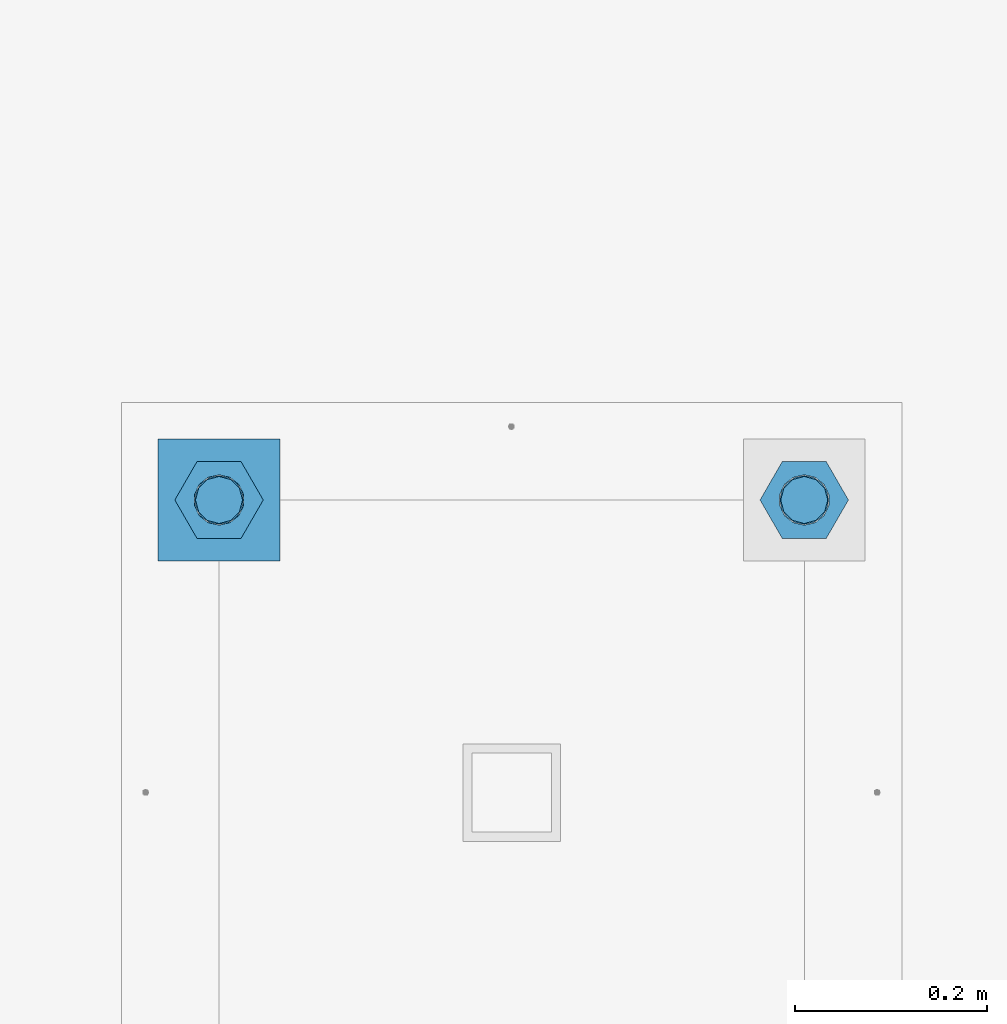
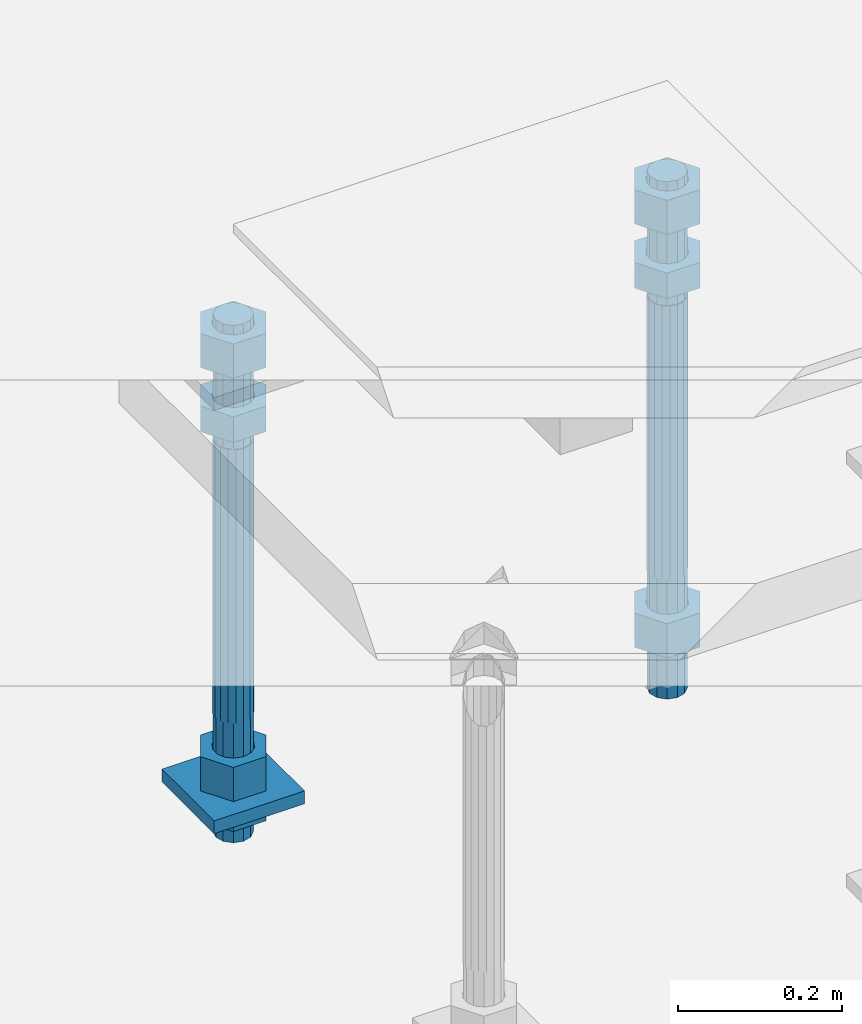
# One storey, part 2715 of 3843: 10 beams, 1 element without a shape of its own.
"""IFC2X3 building model written with IfcOpenShell, lengths in millimetres."""

from ifc_helpers import new_model, si_unit, frame, origin_with_axes, place, context, subcontext, project, spatial, faceted_brep, material, type_object, element, aggregate, save


model = new_model("IFC2X3")

# Units and contexts
model_context = context("Model", 3, precision=1e-05, world=origin_with_axes())
body_context = subcontext(model_context, "Body", "Model", "MODEL_VIEW")
ifc_project = project(units=[si_unit("LENGTHUNIT", "METRE", prefix="MILLI"), si_unit("AREAUNIT", "SQUARE_METRE"), si_unit("VOLUMEUNIT", "CUBIC_METRE"), si_unit("MASSUNIT", "GRAM", prefix="KILO"), si_unit("TIMEUNIT", "SECOND"), si_unit("PLANEANGLEUNIT", "RADIAN"), si_unit("SOLIDANGLEUNIT", "STERADIAN"), si_unit("THERMODYNAMICTEMPERATUREUNIT", "DEGREE_CELSIUS"), si_unit("LUMINOUSINTENSITYUNIT", "LUMEN")], contexts=[model_context])

# Site, building, storey
site_placement = place(None, origin_with_axes())
site = spatial("IfcSite", under=ifc_project, at=site_placement, CompositionType="ELEMENT")
building_placement = place(site_placement, origin_with_axes())
building = spatial("IfcBuilding", under=site, at=building_placement, Name="Undefined", CompositionType="ELEMENT")
storey_placement = place(building_placement, origin_with_axes())
storey = spatial("IfcBuildingStorey", under=building, at=storey_placement, Name="Undefined", CompositionType="ELEMENT", Elevation=0.0)

# Assembly, beams
assembly_placement = place(storey_placement, origin_with_axes())
assembly = element("IfcElementAssembly", 1, at=assembly_placement, inside=storey, Name="TEMPLATE", AssemblyPlace="NOTDEFINED", PredefinedType="RIGID_FRAME")
ifc_material_1 = material(Name="STEEL/A36")
beam_type_1 = type_object("IfcBeamType", PredefinedType="NOTDEFINED")
beam_1_placement = place(assembly_placement, frame((108648.5, 48869.6000015259, 29244.925), z_axis=(1.0, 0.0, 0.0), x_axis=(0.0, 1.0, 0.0)))
beam_1 = element("IfcBeam", 2, at=beam_1_placement, type_object=beam_type_1, material=ifc_material_1, Name="WASHER_PLATE", context=body_context, shape_type="Brep", body=[
    faceted_brep([(0.0, 9.52500000000146, -63.5), (0.0, 9.52500000000146, 63.5), (127.0, 9.52500000000146, 63.5), (127.0, 9.52500000000146, -63.5), (0.0, -9.52500000000146, 63.5), (127.0, -9.52500000000146, 63.5), (0.0, -9.52500000000146, -63.5), (127.0, -9.52500000000146, -63.5)], [[[0, 1, 2, 3]], [[1, 4, 5, 2]], [[4, 6, 7, 5]], [[6, 0, 3, 7]], [[5, 7, 3, 2]], [[6, 4, 1, 0]]]),
])
beam_type_2 = type_object("IfcBeamType", Name="2_HALF_NUT", PredefinedType="NOTDEFINED")
beam_2_placement = place(assembly_placement, frame((108648.5, 48933.1000015259, 29235.4), z_axis=(0.0, 1.0, 0.0), x_axis=(0.0, 0.0, -1.0)))
beam_2 = element("IfcBeam", 3, at=beam_2_placement, type_object=beam_type_2, material=ifc_material_1, Name="NUT", ObjectType="2_HALF_NUT", context=body_context, shape_type="Brep", body=[
    faceted_brep([(0.0, -46.0369987487793, 0.0), (0.0, -23.0184993743896, -39.869213104248), (25.4000000000015, -23.0184993743896, -39.869213104248), (25.4000000000015, -46.0369987487793, 0.0), (0.0, 23.0184993743896, -39.869213104248), (25.4000000000015, 23.0184993743896, -39.869213104248), (0.0, 46.0369987487793, 0.0), (25.4000000000015, 46.0369987487793, 0.0), (0.0, 23.0184993743896, 39.869213104248), (25.4000000000015, 23.0184993743896, 39.869213104248), (0.0, -23.0184993743896, 39.869213104248), (25.4000000000015, -23.0184993743896, 39.869213104248), (0.0, 0.0, 26.1940002441406), (0.0, 11.3650617044477, 23.5999013092805), (25.4000000000015, 11.3650617044477, 23.5999013092805), (25.4000000000015, 0.0, 26.1940002441406), (0.0, 20.4791109456419, 16.3316083006721), (25.4000000000015, 20.4791109456419, 16.3316083006721), (0.0, 25.5370200498292, 5.82867859874386), (25.4000000000015, 25.5370200498292, 5.82867859874386), (0.0, 25.5370200498292, -5.82867859874386), (25.4000000000015, 25.5370200498292, -5.82867859874386), (0.0, 20.4791109456419, -16.3316083006721), (25.4000000000015, 20.4791109456419, -16.3316083006721), (0.0, 11.3650617044477, -23.5999013092805), (25.4000000000015, 11.3650617044477, -23.5999013092805), (0.0, 0.0, -26.1940002441406), (25.4000000000015, 0.0, -26.1940002441406), (0.0, -11.3650617044477, -23.5999013092805), (25.4000000000015, -11.3650617044477, -23.5999013092805), (0.0, -20.4791109456419, -16.3316083006721), (25.4000000000015, -20.4791109456419, -16.3316083006721), (0.0, -25.5370200498292, -5.82867859874386), (25.4000000000015, -25.5370200498292, -5.82867859874386), (0.0, -25.5370200498292, 5.82867859874386), (25.4000000000015, -25.5370200498292, 5.82867859874386), (0.0, -20.4791109456419, 16.3316083006721), (25.4000000000015, -20.4791109456419, 16.3316083006721), (0.0, -11.3650617044477, 23.5999013092805), (25.4000000000015, -11.3650617044477, 23.5999013092805)], [[[0, 1, 2, 3]], [[1, 4, 5, 2]], [[4, 6, 7, 5]], [[6, 8, 9, 7]], [[8, 10, 11, 9]], [[10, 0, 3, 11]], [[12, 13, 14, 15]], [[13, 16, 17, 14]], [[16, 18, 19, 17]], [[18, 20, 21, 19]], [[20, 22, 23, 21]], [[22, 24, 25, 23]], [[24, 26, 27, 25]], [[26, 28, 29, 27]], [[28, 30, 31, 29]], [[30, 32, 33, 31]], [[32, 34, 35, 33]], [[34, 36, 37, 35]], [[36, 38, 39, 37]], [[38, 12, 15, 39]], [[5, 7, 9, 11, 3, 2], [17, 19, 21, 23, 25, 27, 29, 31, 33, 35, 37, 39, 15, 14]], [[10, 8, 6, 4, 1, 0], [38, 36, 34, 32, 30, 28, 26, 24, 22, 20, 18, 16, 13, 12]]]),
])
beam_type_3 = type_object("IfcBeamType", Name="2_HEAVY_HEX_NUT", PredefinedType="NOTDEFINED")
beam_3_placement = place(assembly_placement, frame((108648.5, 48933.1000015259, 29825.95), z_axis=(0.0, 1.0, 0.0), x_axis=(0.0, 0.0, -1.0)))
beam_3 = element("IfcBeam", 4, at=beam_3_placement, type_object=beam_type_3, material=ifc_material_1, Name="NUT", ObjectType="2_HEAVY_HEX_NUT", context=body_context, shape_type="Brep", body=[
    faceted_brep([(0.0, -46.0369987487793, 0.0), (0.0, -23.0184993743896, -39.869213104248), (38.0999999999985, -23.0184993743896, -39.869213104248), (38.0999999999985, -46.0369987487793, 0.0), (0.0, 23.0184993743896, -39.869213104248), (38.0999999999985, 23.0184993743896, -39.869213104248), (0.0, 46.0369987487793, 0.0), (38.0999999999985, 46.0369987487793, 0.0), (0.0, 23.0184993743896, 39.869213104248), (38.0999999999985, 23.0184993743896, 39.869213104248), (0.0, -23.0184993743896, 39.869213104248), (38.0999999999985, -23.0184993743896, 39.869213104248), (0.0, 0.0, 26.1940002441406), (0.0, 11.3650617044477, 23.5999013092805), (38.0999999999985, 11.3650617044477, 23.5999013092805), (38.0999999999985, 0.0, 26.1940002441406), (0.0, 20.4791109456419, 16.3316083006721), (38.0999999999985, 20.4791109456419, 16.3316083006721), (0.0, 25.5370200498292, 5.82867859874386), (38.0999999999985, 25.5370200498292, 5.82867859874386), (0.0, 25.5370200498292, -5.82867859874386), (38.0999999999985, 25.5370200498292, -5.82867859874386), (0.0, 20.4791109456419, -16.3316083006721), (38.0999999999985, 20.4791109456419, -16.3316083006721), (0.0, 11.3650617044477, -23.5999013092805), (38.0999999999985, 11.3650617044477, -23.5999013092805), (0.0, 0.0, -26.1940002441406), (38.0999999999985, 0.0, -26.1940002441406), (0.0, -11.3650617044477, -23.5999013092805), (38.0999999999985, -11.3650617044477, -23.5999013092805), (0.0, -20.4791109456419, -16.3316083006721), (38.0999999999985, -20.4791109456419, -16.3316083006721), (0.0, -25.5370200498292, -5.82867859874386), (38.0999999999985, -25.5370200498292, -5.82867859874386), (0.0, -25.5370200498292, 5.82867859874386), (38.0999999999985, -25.5370200498292, 5.82867859874386), (0.0, -20.4791109456419, 16.3316083006721), (38.0999999999985, -20.4791109456419, 16.3316083006721), (0.0, -11.3650617044477, 23.5999013092805), (38.0999999999985, -11.3650617044477, 23.5999013092805)], [[[0, 1, 2, 3]], [[1, 4, 5, 2]], [[4, 6, 7, 5]], [[6, 8, 9, 7]], [[8, 10, 11, 9]], [[10, 0, 3, 11]], [[12, 13, 14, 15]], [[13, 16, 17, 14]], [[16, 18, 19, 17]], [[18, 20, 21, 19]], [[20, 22, 23, 21]], [[22, 24, 25, 23]], [[24, 26, 27, 25]], [[26, 28, 29, 27]], [[28, 30, 31, 29]], [[30, 32, 33, 31]], [[32, 34, 35, 33]], [[34, 36, 37, 35]], [[36, 38, 39, 37]], [[38, 12, 15, 39]], [[5, 7, 9, 11, 3, 2], [17, 19, 21, 23, 25, 27, 29, 31, 33, 35, 37, 39, 15, 14]], [[10, 8, 6, 4, 1, 0], [38, 36, 34, 32, 30, 28, 26, 24, 22, 20, 18, 16, 13, 12]]]),
])
beam_4_placement = place(assembly_placement, frame((108648.5, 48933.1000015259, 29933.9), z_axis=(0.0, 1.0, 0.0), x_axis=(0.0, 0.0, -1.0)))
beam_4 = element("IfcBeam", 5, at=beam_4_placement, type_object=beam_type_3, material=ifc_material_1, Name="NUT", ObjectType="2_HEAVY_HEX_NUT", context=body_context, shape_type="Brep", body=[
    faceted_brep([(0.0, -46.0369987487793, 0.0), (0.0, -23.0184993743896, -39.869213104248), (50.7999999999993, -23.0184993743896, -39.869213104248), (50.7999999999993, -46.0369987487793, 0.0), (0.0, 23.0184993743896, -39.869213104248), (50.7999999999993, 23.0184993743896, -39.869213104248), (0.0, 46.0369987487793, 0.0), (50.7999999999993, 46.0369987487793, 0.0), (0.0, 23.0184993743896, 39.869213104248), (50.7999999999993, 23.0184993743896, 39.869213104248), (0.0, -23.0184993743896, 39.869213104248), (50.7999999999993, -23.0184993743896, 39.869213104248), (0.0, 0.0, 26.1940002441406), (0.0, 11.3650617044477, 23.5999013092805), (50.7999999999993, 11.3650617044477, 23.5999013092805), (50.7999999999993, 0.0, 26.1940002441406), (0.0, 20.4791109456419, 16.3316083006721), (50.7999999999993, 20.4791109456419, 16.3316083006721), (0.0, 25.5370200498292, 5.82867859874386), (50.7999999999993, 25.5370200498292, 5.82867859874386), (0.0, 25.5370200498292, -5.82867859874386), (50.7999999999993, 25.5370200498292, -5.82867859874386), (0.0, 20.4791109456419, -16.3316083006721), (50.7999999999993, 20.4791109456419, -16.3316083006721), (0.0, 11.3650617044477, -23.5999013092805), (50.7999999999993, 11.3650617044477, -23.5999013092805), (0.0, 0.0, -26.1940002441406), (50.7999999999993, 0.0, -26.1940002441406), (0.0, -11.3650617044477, -23.5999013092805), (50.7999999999993, -11.3650617044477, -23.5999013092805), (0.0, -20.4791109456419, -16.3316083006721), (50.7999999999993, -20.4791109456419, -16.3316083006721), (0.0, -25.5370200498292, -5.82867859874386), (50.7999999999993, -25.5370200498292, -5.82867859874386), (0.0, -25.5370200498292, 5.82867859874386), (50.7999999999993, -25.5370200498292, 5.82867859874386), (0.0, -20.4791109456419, 16.3316083006721), (50.7999999999993, -20.4791109456419, 16.3316083006721), (0.0, -11.3650617044477, 23.5999013092805), (50.7999999999993, -11.3650617044477, 23.5999013092805)], [[[0, 1, 2, 3]], [[1, 4, 5, 2]], [[4, 6, 7, 5]], [[6, 8, 9, 7]], [[8, 10, 11, 9]], [[10, 0, 3, 11]], [[12, 13, 14, 15]], [[13, 16, 17, 14]], [[16, 18, 19, 17]], [[18, 20, 21, 19]], [[20, 22, 23, 21]], [[22, 24, 25, 23]], [[24, 26, 27, 25]], [[26, 28, 29, 27]], [[28, 30, 31, 29]], [[30, 32, 33, 31]], [[32, 34, 35, 33]], [[34, 36, 37, 35]], [[36, 38, 39, 37]], [[38, 12, 15, 39]], [[5, 7, 9, 11, 3, 2], [17, 19, 21, 23, 25, 27, 29, 31, 33, 35, 37, 39, 15, 14]], [[10, 8, 6, 4, 1, 0], [38, 36, 34, 32, 30, 28, 26, 24, 22, 20, 18, 16, 13, 12]]]),
])
beam_5_placement = place(assembly_placement, frame((108648.5, 48933.1000015259, 29305.25), z_axis=(0.0, 1.0, 0.0), x_axis=(0.0, 0.0, -1.0)))
beam_5 = element("IfcBeam", 6, at=beam_5_placement, type_object=beam_type_3, material=ifc_material_1, Name="NUT", ObjectType="2_HEAVY_HEX_NUT", context=body_context, shape_type="Brep", body=[
    faceted_brep([(0.0, -46.0369987487793, 0.0), (0.0, -23.0184993743896, -39.869213104248), (50.7999999999993, -23.0184993743896, -39.869213104248), (50.7999999999993, -46.0369987487793, 0.0), (0.0, 23.0184993743896, -39.869213104248), (50.7999999999993, 23.0184993743896, -39.869213104248), (0.0, 46.0369987487793, 0.0), (50.7999999999993, 46.0369987487793, 0.0), (0.0, 23.0184993743896, 39.869213104248), (50.7999999999993, 23.0184993743896, 39.869213104248), (0.0, -23.0184993743896, 39.869213104248), (50.7999999999993, -23.0184993743896, 39.869213104248), (0.0, 0.0, 26.1940002441406), (0.0, 11.3650617044477, 23.5999013092805), (50.7999999999993, 11.3650617044477, 23.5999013092805), (50.7999999999993, 0.0, 26.1940002441406), (0.0, 20.4791109456419, 16.3316083006721), (50.7999999999993, 20.4791109456419, 16.3316083006721), (0.0, 25.5370200498292, 5.82867859874386), (50.7999999999993, 25.5370200498292, 5.82867859874386), (0.0, 25.5370200498292, -5.82867859874386), (50.7999999999993, 25.5370200498292, -5.82867859874386), (0.0, 20.4791109456419, -16.3316083006721), (50.7999999999993, 20.4791109456419, -16.3316083006721), (0.0, 11.3650617044477, -23.5999013092805), (50.7999999999993, 11.3650617044477, -23.5999013092805), (0.0, 0.0, -26.1940002441406), (50.7999999999993, 0.0, -26.1940002441406), (0.0, -11.3650617044477, -23.5999013092805), (50.7999999999993, -11.3650617044477, -23.5999013092805), (0.0, -20.4791109456419, -16.3316083006721), (50.7999999999993, -20.4791109456419, -16.3316083006721), (0.0, -25.5370200498292, -5.82867859874386), (50.7999999999993, -25.5370200498292, -5.82867859874386), (0.0, -25.5370200498292, 5.82867859874386), (50.7999999999993, -25.5370200498292, 5.82867859874386), (0.0, -20.4791109456419, 16.3316083006721), (50.7999999999993, -20.4791109456419, 16.3316083006721), (0.0, -11.3650617044477, 23.5999013092805), (50.7999999999993, -11.3650617044477, 23.5999013092805)], [[[0, 1, 2, 3]], [[1, 4, 5, 2]], [[4, 6, 7, 5]], [[6, 8, 9, 7]], [[8, 10, 11, 9]], [[10, 0, 3, 11]], [[12, 13, 14, 15]], [[13, 16, 17, 14]], [[16, 18, 19, 17]], [[18, 20, 21, 19]], [[20, 22, 23, 21]], [[22, 24, 25, 23]], [[24, 26, 27, 25]], [[26, 28, 29, 27]], [[28, 30, 31, 29]], [[30, 32, 33, 31]], [[32, 34, 35, 33]], [[34, 36, 37, 35]], [[36, 38, 39, 37]], [[38, 12, 15, 39]], [[5, 7, 9, 11, 3, 2], [17, 19, 21, 23, 25, 27, 29, 31, 33, 35, 37, 39, 15, 14]], [[10, 8, 6, 4, 1, 0], [38, 36, 34, 32, 30, 28, 26, 24, 22, 20, 18, 16, 13, 12]]]),
])
beam_6_placement = place(assembly_placement, frame((109258.1, 48933.1000015259, 29825.95), z_axis=(0.0, 1.0, 0.0), x_axis=(0.0, 0.0, -1.0)))
beam_6 = element("IfcBeam", 7, at=beam_6_placement, type_object=beam_type_3, material=ifc_material_1, Name="NUT", ObjectType="2_HEAVY_HEX_NUT", context=body_context, shape_type="Brep", body=[
    faceted_brep([(0.0, -46.0369987487793, 0.0), (0.0, -23.0184993743896, -39.869213104248), (38.0999999999985, -23.0184993743896, -39.869213104248), (38.0999999999985, -46.0369987487793, 0.0), (0.0, 23.0184993743896, -39.869213104248), (38.0999999999985, 23.0184993743896, -39.869213104248), (0.0, 46.0369987487793, 0.0), (38.0999999999985, 46.0369987487793, 0.0), (0.0, 23.0184993743896, 39.869213104248), (38.0999999999985, 23.0184993743896, 39.869213104248), (0.0, -23.0184993743896, 39.869213104248), (38.0999999999985, -23.0184993743896, 39.869213104248), (0.0, 0.0, 26.1940002441406), (0.0, 11.3650617044477, 23.5999013092805), (38.0999999999985, 11.3650617044477, 23.5999013092805), (38.0999999999985, 0.0, 26.1940002441406), (0.0, 20.4791109456419, 16.3316083006721), (38.0999999999985, 20.4791109456419, 16.3316083006721), (0.0, 25.5370200498292, 5.82867859874386), (38.0999999999985, 25.5370200498292, 5.82867859874386), (0.0, 25.5370200498292, -5.82867859874386), (38.0999999999985, 25.5370200498292, -5.82867859874386), (0.0, 20.4791109456419, -16.3316083006721), (38.0999999999985, 20.4791109456419, -16.3316083006721), (0.0, 11.3650617044477, -23.5999013092805), (38.0999999999985, 11.3650617044477, -23.5999013092805), (0.0, 0.0, -26.1940002441406), (38.0999999999985, 0.0, -26.1940002441406), (0.0, -11.3650617044477, -23.5999013092805), (38.0999999999985, -11.3650617044477, -23.5999013092805), (0.0, -20.4791109456419, -16.3316083006721), (38.0999999999985, -20.4791109456419, -16.3316083006721), (0.0, -25.5370200498292, -5.82867859874386), (38.0999999999985, -25.5370200498292, -5.82867859874386), (0.0, -25.5370200498292, 5.82867859874386), (38.0999999999985, -25.5370200498292, 5.82867859874386), (0.0, -20.4791109456419, 16.3316083006721), (38.0999999999985, -20.4791109456419, 16.3316083006721), (0.0, -11.3650617044477, 23.5999013092805), (38.0999999999985, -11.3650617044477, 23.5999013092805)], [[[0, 1, 2, 3]], [[1, 4, 5, 2]], [[4, 6, 7, 5]], [[6, 8, 9, 7]], [[8, 10, 11, 9]], [[10, 0, 3, 11]], [[12, 13, 14, 15]], [[13, 16, 17, 14]], [[16, 18, 19, 17]], [[18, 20, 21, 19]], [[20, 22, 23, 21]], [[22, 24, 25, 23]], [[24, 26, 27, 25]], [[26, 28, 29, 27]], [[28, 30, 31, 29]], [[30, 32, 33, 31]], [[32, 34, 35, 33]], [[34, 36, 37, 35]], [[36, 38, 39, 37]], [[38, 12, 15, 39]], [[5, 7, 9, 11, 3, 2], [17, 19, 21, 23, 25, 27, 29, 31, 33, 35, 37, 39, 15, 14]], [[10, 8, 6, 4, 1, 0], [38, 36, 34, 32, 30, 28, 26, 24, 22, 20, 18, 16, 13, 12]]]),
])
beam_7_placement = place(assembly_placement, frame((109258.1, 48933.1000015259, 29933.9), z_axis=(0.0, 1.0, 0.0), x_axis=(0.0, 0.0, -1.0)))
beam_7 = element("IfcBeam", 8, at=beam_7_placement, type_object=beam_type_3, material=ifc_material_1, Name="NUT", ObjectType="2_HEAVY_HEX_NUT", context=body_context, shape_type="Brep", body=[
    faceted_brep([(0.0, -46.0369987487793, 0.0), (0.0, -23.0184993743896, -39.869213104248), (50.7999999999993, -23.0184993743896, -39.869213104248), (50.7999999999993, -46.0369987487793, 0.0), (0.0, 23.0184993743896, -39.869213104248), (50.7999999999993, 23.0184993743896, -39.869213104248), (0.0, 46.0369987487793, 0.0), (50.7999999999993, 46.0369987487793, 0.0), (0.0, 23.0184993743896, 39.869213104248), (50.7999999999993, 23.0184993743896, 39.869213104248), (0.0, -23.0184993743896, 39.869213104248), (50.7999999999993, -23.0184993743896, 39.869213104248), (0.0, 0.0, 26.1940002441406), (0.0, 11.3650617044477, 23.5999013092805), (50.7999999999993, 11.3650617044477, 23.5999013092805), (50.7999999999993, 0.0, 26.1940002441406), (0.0, 20.4791109456419, 16.3316083006721), (50.7999999999993, 20.4791109456419, 16.3316083006721), (0.0, 25.5370200498292, 5.82867859874386), (50.7999999999993, 25.5370200498292, 5.82867859874386), (0.0, 25.5370200498292, -5.82867859874386), (50.7999999999993, 25.5370200498292, -5.82867859874386), (0.0, 20.4791109456419, -16.3316083006721), (50.7999999999993, 20.4791109456419, -16.3316083006721), (0.0, 11.3650617044477, -23.5999013092805), (50.7999999999993, 11.3650617044477, -23.5999013092805), (0.0, 0.0, -26.1940002441406), (50.7999999999993, 0.0, -26.1940002441406), (0.0, -11.3650617044477, -23.5999013092805), (50.7999999999993, -11.3650617044477, -23.5999013092805), (0.0, -20.4791109456419, -16.3316083006721), (50.7999999999993, -20.4791109456419, -16.3316083006721), (0.0, -25.5370200498292, -5.82867859874386), (50.7999999999993, -25.5370200498292, -5.82867859874386), (0.0, -25.5370200498292, 5.82867859874386), (50.7999999999993, -25.5370200498292, 5.82867859874386), (0.0, -20.4791109456419, 16.3316083006721), (50.7999999999993, -20.4791109456419, 16.3316083006721), (0.0, -11.3650617044477, 23.5999013092805), (50.7999999999993, -11.3650617044477, 23.5999013092805)], [[[0, 1, 2, 3]], [[1, 4, 5, 2]], [[4, 6, 7, 5]], [[6, 8, 9, 7]], [[8, 10, 11, 9]], [[10, 0, 3, 11]], [[12, 13, 14, 15]], [[13, 16, 17, 14]], [[16, 18, 19, 17]], [[18, 20, 21, 19]], [[20, 22, 23, 21]], [[22, 24, 25, 23]], [[24, 26, 27, 25]], [[26, 28, 29, 27]], [[28, 30, 31, 29]], [[30, 32, 33, 31]], [[32, 34, 35, 33]], [[34, 36, 37, 35]], [[36, 38, 39, 37]], [[38, 12, 15, 39]], [[5, 7, 9, 11, 3, 2], [17, 19, 21, 23, 25, 27, 29, 31, 33, 35, 37, 39, 15, 14]], [[10, 8, 6, 4, 1, 0], [38, 36, 34, 32, 30, 28, 26, 24, 22, 20, 18, 16, 13, 12]]]),
])
beam_8_placement = place(assembly_placement, frame((109258.1, 48933.1000015259, 29305.25), z_axis=(0.0, 1.0, 0.0), x_axis=(0.0, 0.0, -1.0)))
beam_8 = element("IfcBeam", 9, at=beam_8_placement, type_object=beam_type_3, material=ifc_material_1, Name="NUT", ObjectType="2_HEAVY_HEX_NUT", context=body_context, shape_type="Brep", body=[
    faceted_brep([(0.0, -46.0369987487793, 0.0), (0.0, -23.0184993743896, -39.869213104248), (50.7999999999993, -23.0184993743896, -39.869213104248), (50.7999999999993, -46.0369987487793, 0.0), (0.0, 23.0184993743896, -39.869213104248), (50.7999999999993, 23.0184993743896, -39.869213104248), (0.0, 46.0369987487793, 0.0), (50.7999999999993, 46.0369987487793, 0.0), (0.0, 23.0184993743896, 39.869213104248), (50.7999999999993, 23.0184993743896, 39.869213104248), (0.0, -23.0184993743896, 39.869213104248), (50.7999999999993, -23.0184993743896, 39.869213104248), (0.0, 0.0, 26.1940002441406), (0.0, 11.3650617044477, 23.5999013092805), (50.7999999999993, 11.3650617044477, 23.5999013092805), (50.7999999999993, 0.0, 26.1940002441406), (0.0, 20.4791109456419, 16.3316083006721), (50.7999999999993, 20.4791109456419, 16.3316083006721), (0.0, 25.5370200498292, 5.82867859874386), (50.7999999999993, 25.5370200498292, 5.82867859874386), (0.0, 25.5370200498292, -5.82867859874386), (50.7999999999993, 25.5370200498292, -5.82867859874386), (0.0, 20.4791109456419, -16.3316083006721), (50.7999999999993, 20.4791109456419, -16.3316083006721), (0.0, 11.3650617044477, -23.5999013092805), (50.7999999999993, 11.3650617044477, -23.5999013092805), (0.0, 0.0, -26.1940002441406), (50.7999999999993, 0.0, -26.1940002441406), (0.0, -11.3650617044477, -23.5999013092805), (50.7999999999993, -11.3650617044477, -23.5999013092805), (0.0, -20.4791109456419, -16.3316083006721), (50.7999999999993, -20.4791109456419, -16.3316083006721), (0.0, -25.5370200498292, -5.82867859874386), (50.7999999999993, -25.5370200498292, -5.82867859874386), (0.0, -25.5370200498292, 5.82867859874386), (50.7999999999993, -25.5370200498292, 5.82867859874386), (0.0, -20.4791109456419, 16.3316083006721), (50.7999999999993, -20.4791109456419, 16.3316083006721), (0.0, -11.3650617044477, 23.5999013092805), (50.7999999999993, -11.3650617044477, 23.5999013092805)], [[[0, 1, 2, 3]], [[1, 4, 5, 2]], [[4, 6, 7, 5]], [[6, 8, 9, 7]], [[8, 10, 11, 9]], [[10, 0, 3, 11]], [[12, 13, 14, 15]], [[13, 16, 17, 14]], [[16, 18, 19, 17]], [[18, 20, 21, 19]], [[20, 22, 23, 21]], [[22, 24, 25, 23]], [[24, 26, 27, 25]], [[26, 28, 29, 27]], [[28, 30, 31, 29]], [[30, 32, 33, 31]], [[32, 34, 35, 33]], [[34, 36, 37, 35]], [[36, 38, 39, 37]], [[38, 12, 15, 39]], [[5, 7, 9, 11, 3, 2], [17, 19, 21, 23, 25, 27, 29, 31, 33, 35, 37, 39, 15, 14]], [[10, 8, 6, 4, 1, 0], [38, 36, 34, 32, 30, 28, 26, 24, 22, 20, 18, 16, 13, 12]]]),
])
ifc_material_2 = material()
beam_type_4 = type_object("IfcBeamType", PredefinedType="NOTDEFINED")
beam_9_placement = place(assembly_placement, frame((108648.5, 48933.1000015259, 29762.45), z_axis=(0.0, 1.0, 0.0), x_axis=(0.0, 0.0, -1.0)))
beam_9 = element("IfcBeam", 10, at=beam_9_placement, type_object=beam_type_4, material=ifc_material_2, Name="ANCHOR_ROD", context=body_context, shape_type="Brep", body=[
    faceted_brep([(-184.150000000001, -21.217622392709, 12.25), (-184.150000000001, -12.2499999999854, 21.2176223927163), (-184.150000000001, 1.45519152283669e-11, 24.5), (-184.150000000001, 12.2500000000146, 21.2176223927163), (-184.150000000001, 21.2176223927381, 12.25), (-184.150000000001, 24.5000000000146, 0.0), (-184.150000000001, 21.2176223927381, -12.25), (-184.150000000001, 12.2500000000146, -21.2176223927163), (-184.150000000001, 1.45519152283669e-11, -24.5), (-184.150000000001, -12.2499999999854, -21.2176223927163), (-184.150000000001, -21.217622392709, -12.25), (-184.150000000001, -24.4999999999854, 0.0), (0.0, 24.5000000000146, 0.0), (0.0, 21.2176223927381, -12.25), (0.0, 12.2500000000146, -21.2176223927163), (0.0, 1.45519152283669e-11, -24.5), (0.0, -12.2499999999854, -21.2176223927163), (0.0, -21.217622392709, -12.25), (0.0, -24.4999999999854, 0.0), (0.0, -21.217622392709, 12.25), (0.0, -12.2499999999854, 21.2176223927163), (0.0, 1.45519152283669e-11, 24.5), (0.0, 12.2500000000146, 21.2176223927163), (0.0, 21.2176223927381, 12.25), (0.0, -23.4665401257807, 9.72015918207035), (0.0, -17.9605122421344, 17.9605122421417), (0.0, -9.72015918207762, 23.466540125788), (0.0, 0.0, 25.4000000000015), (0.0, 9.72015918207762, 23.466540125788), (0.0, 17.9605122421344, 17.9605122421417), (0.0, 23.4665401257807, 9.72015918207035), (0.0, 25.3999996185303, 0.0), (0.0, 23.4665401257807, -9.72015918207035), (0.0, 17.9605122421344, -17.9605122421417), (0.0, 9.72015918207762, -23.466540125788), (0.0, 0.0, -25.4000000000015), (0.0, -9.72015918207762, -23.466540125788), (0.0, -17.9605122421344, -17.9605122421417), (0.0, -23.4665401257807, -9.72015918207035), (0.0, -25.3999996185303, 0.0), (406.399999999998, -25.3999999999942, 0.0), (406.399999999998, -23.4665401257807, 9.72015918207035), (406.399999999998, -17.9605122421344, 17.9605122421417), (406.399999999998, -9.72015918207762, 23.466540125788), (406.399999999998, 0.0, 25.4000000000015), (406.399999999998, 9.72015918207762, 23.466540125788), (406.399999999998, 17.9605122421344, 17.9605122421417), (406.399999999998, 23.4665401257807, 9.72015918207035), (406.399999999998, 25.3999999999942, 0.0), (406.399999999998, 23.4665401257807, -9.72015918207035), (406.399999999998, 17.9605122421344, -17.9605122421417), (406.399999999998, 9.72015918207762, -23.466540125788), (406.399999999998, 0.0, -25.4000000000015), (406.399999999998, -9.72015918207762, -23.466540125788), (406.399999999998, -17.9605122421344, -17.9605122421417), (406.399999999998, -23.4665401257807, -9.72015918207035), (406.399999999998, -12.2499999999854, 21.2176223927163), (406.399999999998, 1.45519152283669e-11, 24.5), (406.399999999998, 12.2500000000146, 21.2176223927163), (406.399999999998, 21.2176223927381, 12.25), (406.399999999998, 24.5000000000146, 0.0), (406.399999999998, 21.2176223927381, -12.25), (406.399999999998, 12.2500000000146, -21.2176223927163), (406.399999999998, 1.45519152283669e-11, -24.5), (406.399999999998, -12.2499999999854, -21.2176223927163), (406.399999999998, -21.217622392709, -12.25), (406.399999999998, -24.4999999999854, 0.0), (406.399999999998, -21.217622392709, 12.25), (584.200000000001, -12.2499999999854, -21.2176223927163), (584.200000000001, 1.45519152283669e-11, -24.5), (584.200000000001, 12.2500000000146, -21.2176223927163), (584.200000000001, 21.2176223927381, -12.25), (584.200000000001, 24.5000000000146, 0.0), (584.200000000001, 21.2176223927381, 12.25), (584.200000000001, 12.2500000000146, 21.2176223927163), (584.200000000001, 1.45519152283669e-11, 24.5), (584.200000000001, -12.2499999999854, 21.2176223927163), (584.200000000001, -21.217622392709, 12.25), (584.200000000001, -24.4999999999854, 0.0), (584.200000000001, -21.217622392709, -12.25)], [[[0, 1, 2, 3, 4, 5, 6, 7, 8, 9, 10, 11]], [[6, 5, 12, 13]], [[7, 6, 13, 14]], [[8, 7, 14, 15]], [[9, 8, 15, 16]], [[10, 9, 16, 17]], [[11, 10, 17, 18]], [[0, 11, 18, 19]], [[1, 0, 19, 20]], [[2, 1, 20, 21]], [[3, 2, 21, 22]], [[4, 3, 22, 23]], [[5, 4, 23, 12]], [[24, 25, 26, 27, 28, 29, 30, 31, 32, 33, 34, 35, 36, 37, 38, 39], [22, 21, 20, 19, 18, 17, 16, 15, 14, 13, 12, 23]], [[24, 39, 40, 41]], [[25, 24, 41, 42]], [[26, 25, 42, 43]], [[27, 26, 43, 44]], [[28, 27, 44, 45]], [[29, 28, 45, 46]], [[30, 29, 46, 47]], [[31, 30, 47, 48]], [[32, 31, 48, 49]], [[33, 32, 49, 50]], [[34, 33, 50, 51]], [[35, 34, 51, 52]], [[36, 35, 52, 53]], [[37, 36, 53, 54]], [[38, 37, 54, 55]], [[39, 38, 55, 40]], [[54, 53, 52, 51, 50, 49, 48, 47, 46, 45, 44, 43, 42, 41, 40, 55], [56, 57, 58, 59, 60, 61, 62, 63, 64, 65, 66, 67]], [[68, 69, 70, 71, 72, 73, 74, 75, 76, 77, 78, 79]], [[76, 75, 57, 56]], [[77, 76, 56, 67]], [[78, 77, 67, 66]], [[79, 78, 66, 65]], [[68, 79, 65, 64]], [[69, 68, 64, 63]], [[70, 69, 63, 62]], [[71, 70, 62, 61]], [[72, 71, 61, 60]], [[73, 72, 60, 59]], [[74, 73, 59, 58]], [[75, 74, 58, 57]]]),
])
beam_10_placement = place(assembly_placement, frame((109258.1, 48933.1000015259, 29762.45), z_axis=(0.0, 1.0, 0.0), x_axis=(0.0, 0.0, -1.0)))
beam_10 = element("IfcBeam", 11, at=beam_10_placement, type_object=beam_type_4, material=ifc_material_2, Name="ANCHOR_ROD", context=body_context, shape_type="Brep", body=[
    faceted_brep([(-184.150000000001, -21.217622392709, 12.25), (-184.150000000001, -12.2499999999854, 21.2176223927163), (-184.150000000001, 1.45519152283669e-11, 24.5), (-184.150000000001, 12.2500000000146, 21.2176223927163), (-184.150000000001, 21.2176223927381, 12.25), (-184.150000000001, 24.5000000000146, 0.0), (-184.150000000001, 21.2176223927381, -12.25), (-184.150000000001, 12.2500000000146, -21.2176223927163), (-184.150000000001, 1.45519152283669e-11, -24.5), (-184.150000000001, -12.2499999999854, -21.2176223927163), (-184.150000000001, -21.217622392709, -12.25), (-184.150000000001, -24.4999999999854, 0.0), (0.0, 24.5000000000146, 0.0), (0.0, 21.2176223927381, -12.25), (0.0, 12.2500000000146, -21.2176223927163), (0.0, 1.45519152283669e-11, -24.5), (0.0, -12.2499999999854, -21.2176223927163), (0.0, -21.217622392709, -12.25), (0.0, -24.4999999999854, 0.0), (0.0, -21.217622392709, 12.25), (0.0, -12.2499999999854, 21.2176223927163), (0.0, 1.45519152283669e-11, 24.5), (0.0, 12.2500000000146, 21.2176223927163), (0.0, 21.2176223927381, 12.25), (0.0, -23.4665401257807, 9.72015918207035), (0.0, -17.9605122421344, 17.9605122421417), (0.0, -9.72015918207762, 23.466540125788), (0.0, 0.0, 25.4000000000015), (0.0, 9.72015918207762, 23.466540125788), (0.0, 17.9605122421344, 17.9605122421417), (0.0, 23.4665401257807, 9.72015918207035), (0.0, 25.3999996185303, 0.0), (0.0, 23.4665401257807, -9.72015918207035), (0.0, 17.9605122421344, -17.9605122421417), (0.0, 9.72015918207762, -23.466540125788), (0.0, 0.0, -25.4000000000015), (0.0, -9.72015918207762, -23.466540125788), (0.0, -17.9605122421344, -17.9605122421417), (0.0, -23.4665401257807, -9.72015918207035), (0.0, -25.3999996185303, 0.0), (406.399999999998, -25.3999999999942, 0.0), (406.399999999998, -23.4665401257807, 9.72015918207035), (406.399999999998, -17.9605122421344, 17.9605122421417), (406.399999999998, -9.72015918207762, 23.466540125788), (406.399999999998, 0.0, 25.4000000000015), (406.399999999998, 9.72015918207762, 23.466540125788), (406.399999999998, 17.9605122421344, 17.9605122421417), (406.399999999998, 23.4665401257807, 9.72015918207035), (406.399999999998, 25.3999999999942, 0.0), (406.399999999998, 23.4665401257807, -9.72015918207035), (406.399999999998, 17.9605122421344, -17.9605122421417), (406.399999999998, 9.72015918207762, -23.466540125788), (406.399999999998, 0.0, -25.4000000000015), (406.399999999998, -9.72015918207762, -23.466540125788), (406.399999999998, -17.9605122421344, -17.9605122421417), (406.399999999998, -23.4665401257807, -9.72015918207035), (406.399999999998, -12.2499999999854, 21.2176223927163), (406.399999999998, 1.45519152283669e-11, 24.5), (406.399999999998, 12.2500000000146, 21.2176223927163), (406.399999999998, 21.2176223927381, 12.25), (406.399999999998, 24.5000000000146, 0.0), (406.399999999998, 21.2176223927381, -12.25), (406.399999999998, 12.2500000000146, -21.2176223927163), (406.399999999998, 1.45519152283669e-11, -24.5), (406.399999999998, -12.2499999999854, -21.2176223927163), (406.399999999998, -21.217622392709, -12.25), (406.399999999998, -24.4999999999854, 0.0), (406.399999999998, -21.217622392709, 12.25), (584.200000000001, -12.2499999999854, -21.2176223927163), (584.200000000001, 1.45519152283669e-11, -24.5), (584.200000000001, 12.2500000000146, -21.2176223927163), (584.200000000001, 21.2176223927381, -12.25), (584.200000000001, 24.5000000000146, 0.0), (584.200000000001, 21.2176223927381, 12.25), (584.200000000001, 12.2500000000146, 21.2176223927163), (584.200000000001, 1.45519152283669e-11, 24.5), (584.200000000001, -12.2499999999854, 21.2176223927163), (584.200000000001, -21.217622392709, 12.25), (584.200000000001, -24.4999999999854, 0.0), (584.200000000001, -21.217622392709, -12.25)], [[[0, 1, 2, 3, 4, 5, 6, 7, 8, 9, 10, 11]], [[6, 5, 12, 13]], [[7, 6, 13, 14]], [[8, 7, 14, 15]], [[9, 8, 15, 16]], [[10, 9, 16, 17]], [[11, 10, 17, 18]], [[0, 11, 18, 19]], [[1, 0, 19, 20]], [[2, 1, 20, 21]], [[3, 2, 21, 22]], [[4, 3, 22, 23]], [[5, 4, 23, 12]], [[24, 25, 26, 27, 28, 29, 30, 31, 32, 33, 34, 35, 36, 37, 38, 39], [22, 21, 20, 19, 18, 17, 16, 15, 14, 13, 12, 23]], [[24, 39, 40, 41]], [[25, 24, 41, 42]], [[26, 25, 42, 43]], [[27, 26, 43, 44]], [[28, 27, 44, 45]], [[29, 28, 45, 46]], [[30, 29, 46, 47]], [[31, 30, 47, 48]], [[32, 31, 48, 49]], [[33, 32, 49, 50]], [[34, 33, 50, 51]], [[35, 34, 51, 52]], [[36, 35, 52, 53]], [[37, 36, 53, 54]], [[38, 37, 54, 55]], [[39, 38, 55, 40]], [[54, 53, 52, 51, 50, 49, 48, 47, 46, 45, 44, 43, 42, 41, 40, 55], [56, 57, 58, 59, 60, 61, 62, 63, 64, 65, 66, 67]], [[68, 69, 70, 71, 72, 73, 74, 75, 76, 77, 78, 79]], [[76, 75, 57, 56]], [[77, 76, 56, 67]], [[78, 77, 67, 66]], [[79, 78, 66, 65]], [[68, 79, 65, 64]], [[69, 68, 64, 63]], [[70, 69, 63, 62]], [[71, 70, 62, 61]], [[72, 71, 61, 60]], [[73, 72, 60, 59]], [[74, 73, 59, 58]], [[75, 74, 58, 57]]]),
])
aggregate(assembly, [beam_9, beam_3, beam_4, beam_5, beam_2, beam_1, beam_10, beam_6, beam_7, beam_8])

save(model, "model.ifc")
